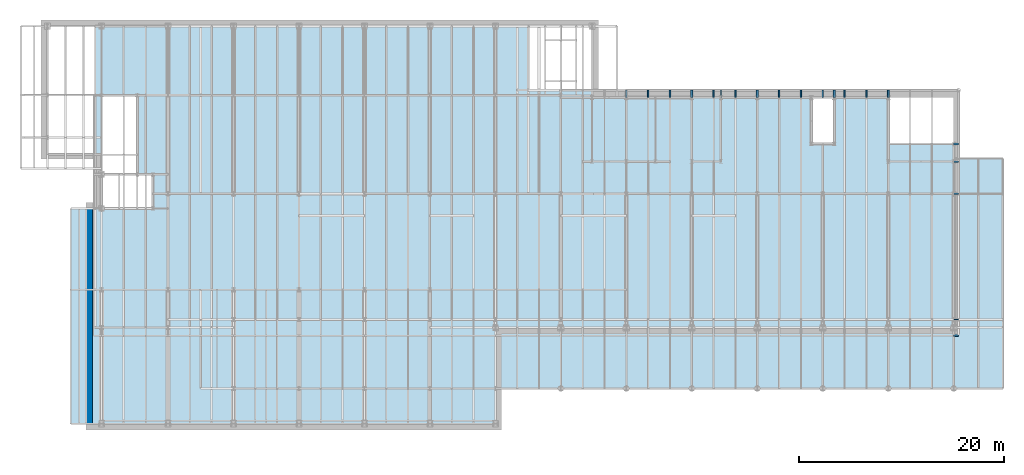
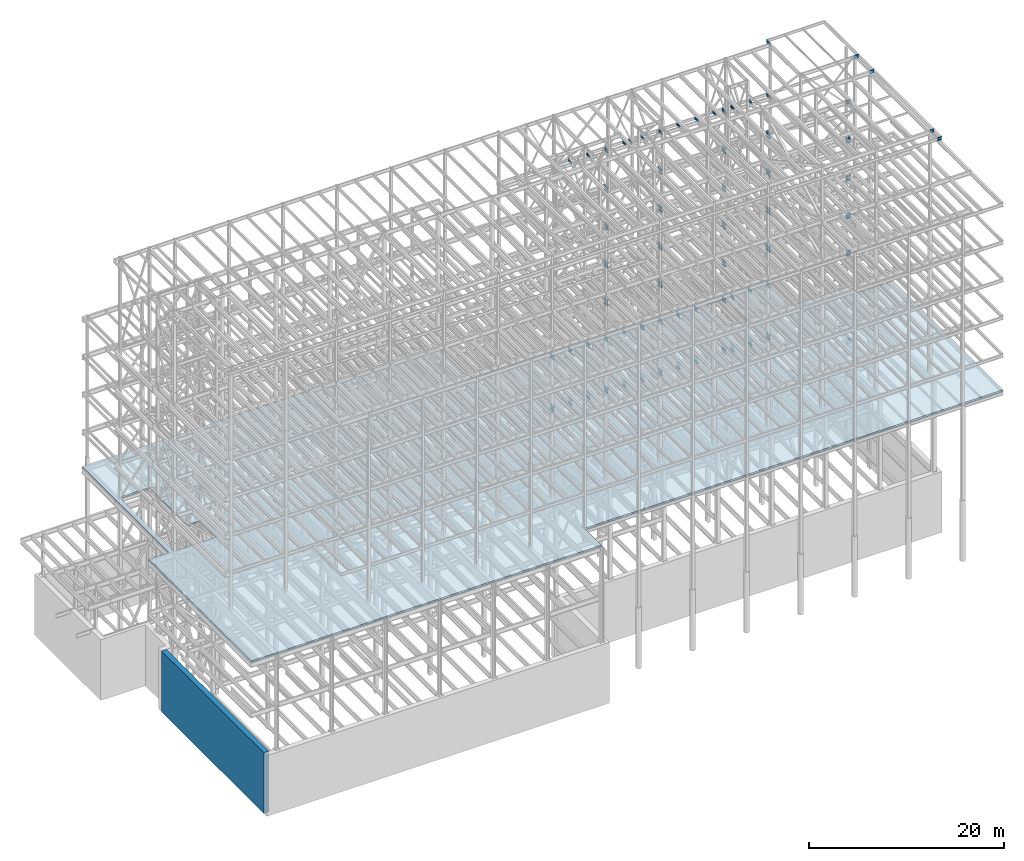
# One storey, part 149 of 150: 67 beams, 1 slab, 1 wall, 2 openings.
"""IFC2X3 building model written with IfcOpenShell, lengths in millimetres."""

from ifc_helpers import new_model, si_unit, frame, frame_2d, origin_with_axes, origin_2d_with_axis, place, context, subcontext, project, spatial, polyline, rectangle, i_section, outline, extrude, material, layer, layer_set, layer_usage, type_object, element, save


model = new_model("IFC2X3")

# Units and contexts
model_context = context("Model", 3, precision=1e-05, world=origin_with_axes())
body_context = subcontext(model_context, "Body", "Model", "MODEL_VIEW")
ifc_project = project(units=[si_unit("LENGTHUNIT", "METRE", prefix="MILLI"), si_unit("AREAUNIT", "SQUARE_METRE"), si_unit("VOLUMEUNIT", "CUBIC_METRE"), si_unit("MASSUNIT", "GRAM", prefix="KILO"), si_unit("TIMEUNIT", "SECOND"), si_unit("PLANEANGLEUNIT", "RADIAN"), si_unit("SOLIDANGLEUNIT", "STERADIAN"), si_unit("THERMODYNAMICTEMPERATUREUNIT", "DEGREE_CELSIUS"), si_unit("LUMINOUSINTENSITYUNIT", "LUMEN")], contexts=[model_context])

# Site, building, storey
site_placement = place(None, origin_with_axes())
site = spatial("IfcSite", under=ifc_project, at=site_placement, CompositionType="ELEMENT")
building_placement = place(site_placement, origin_with_axes())
building = spatial("IfcBuilding", under=site, at=building_placement, Name="Undefined", CompositionType="ELEMENT")
storey_placement = place(building_placement, origin_with_axes())
storey = spatial("IfcBuildingStorey", under=building, at=storey_placement, Name="Undefined", CompositionType="ELEMENT", Elevation=0.0)

# Beams
ifc_material_1 = material(Name="STEEL/A992")
beam_type_1 = type_object("IfcBeamType", Name="W18X35", PredefinedType="NOTDEFINED")
beam_1_placement = place(storey_placement, frame((88595.2, 27355.8, 58981.975), z_axis=(0.0, 0.0, 1.0), x_axis=(1.0, 0.0, 0.0)))
element("IfcBeam", 1, at=beam_1_placement, inside=storey, type_object=beam_type_1, material=ifc_material_1, Name="BEAM", ObjectType="W18X35", context=body_context, shape_type="SweptSolid", body=[
    extrude(i_section(OverallWidth=152.4, OverallDepth=450.85, WebThickness=7.9375, FlangeThickness=10.795, FilletRadius=17.78, at=origin_2d_with_axis()), frame((482.600000000006, 0.0, 0.0), z_axis=(-1.0, 0.0, 0.0), x_axis=(0.0, -1.0, 0.0)), (0.0, 0.0, 1.0), 482.600000000006),
])
beam_2_placement = place(storey_placement, frame((56591.2, 31877.0, 35359.975), z_axis=(0.0, 0.0, 1.0), x_axis=(0.0, 1.0, 0.0)))
element("IfcBeam", 2, at=beam_2_placement, inside=storey, type_object=beam_type_1, material=ifc_material_1, Name="BEAM", ObjectType="W18X35", context=body_context, shape_type="SweptSolid", body=[
    extrude(i_section(OverallWidth=152.4, OverallDepth=450.85, WebThickness=7.9375, FlangeThickness=10.795, FilletRadius=17.78, at=origin_2d_with_axis()), frame((736.599999999991, 0.0, 0.0), z_axis=(-1.0, 0.0, 0.0), x_axis=(0.0, -1.0, 0.0)), (0.0, 0.0, 1.0), 736.599999999991),
])
for number, where, z_axis, x_axis, name in (
    (3, (58724.8, 31877.0, 35359.975), (0.0, 0.0, 1.0), (0.0, 1.0, 0.0), "BEAM"),
    (4, (65125.59935992, 31877.0, 35359.975), (0.0, 0.0, 1.0), (0.0, 1.0, 0.0), "BEAM"),
):
    element("IfcBeam", number, at=place(storey_placement, frame(where, z_axis=z_axis, x_axis=x_axis)), inside=storey, type_object=beam_type_1, material=ifc_material_1, Name=name, ObjectType="W18X35", context=body_context, shape_type="SweptSolid", body=[
        extrude(i_section(OverallWidth=152.4, OverallDepth=450.85, WebThickness=7.9375, FlangeThickness=10.795, FilletRadius=17.78, at=origin_2d_with_axis()), frame((736.599999999991, 0.0, 0.0), z_axis=(-1.0, 0.0, 0.0), x_axis=(0.0, -1.0, 0.0)), (0.0, 0.0, 1.0), 736.599999999988),
    ])
for number, where, z_axis, x_axis, name in (
    (5, (62992.0, 31877.0, 35359.975), (0.0, 0.0, 1.0), (0.0, 1.0, 0.0), "BEAM"),
    (6, (60858.4, 31877.0, 35359.975), (0.0, 0.0, 1.0), (0.0, 1.0, 0.0), "BEAM"),
    (7, (67259.19935992, 31876.9990602, 35359.975), (0.0, 0.0, 1.0), (0.0, 1.0, 0.0), "BEAM"),
    (8, (69392.8, 31877.0, 35359.975), (0.0, 0.0, 1.0), (0.0, 1.0, 0.0), "BEAM"),
    (9, (71526.39935992, 31876.9990602, 35359.975), (0.0, 0.0, 1.0), (0.0, 1.0, 0.0), "BEAM"),
    (10, (73659.99935992, 31876.9990602, 35359.975), (0.0, 0.0, 1.0), (0.0, 1.0, 0.0), "BEAM"),
    (11, (76923.9, 31877.0, 35359.975), (0.0, 0.0, 1.0), (0.0, 1.0, 0.0), "BEAM"),
    (12, (77927.19935992, 31876.9990602, 35359.975), (0.0, 0.0, 1.0), (0.0, 1.0, 0.0), "BEAM"),
    (13, (80060.79935992, 31876.9990602, 35359.975), (0.0, 0.0, 1.0), (0.0, 1.0, 0.0), "BEAM"),
    (14, (82194.4, 31877.0, 35359.975), (0.0, 0.0, 1.0), (0.0, 1.0, 0.0), "BEAM"),
):
    element("IfcBeam", number, at=place(storey_placement, frame(where, z_axis=z_axis, x_axis=x_axis)), inside=storey, type_object=beam_type_1, material=ifc_material_1, Name=name, ObjectType="W18X35", context=body_context, shape_type="SweptSolid", body=[
        extrude(i_section(OverallWidth=152.4, OverallDepth=450.85, WebThickness=7.9375, FlangeThickness=10.795, FilletRadius=17.78, at=origin_2d_with_axis()), frame((736.599999999991, 0.0, 0.0), z_axis=(-1.0, 0.0, 0.0), x_axis=(0.0, -1.0, 0.0)), (0.0, 0.0, 1.0), 736.599999999991),
    ])
beam_type_2 = type_object("IfcBeamType", Name="W24X68", PredefinedType="NOTDEFINED")
for number, where, z_axis, x_axis, name in (
    (15, (62992.0, 31877.0, 54181.375), (0.0, 0.0, 1.0), (0.0, 1.0, 0.0), "BEAM"),
    (16, (69392.8, 31877.0, 54181.375), (0.0, 0.0, 1.0), (0.0, 1.0, 0.0), "BEAM"),
    (17, (82194.4, 31877.0, 54181.375), (0.0, 0.0, 1.0), (0.0, 1.0, 0.0), "BEAM"),
    (18, (76923.9, 31877.0, 54181.375), (0.0, 0.0, 1.0), (0.0, 1.0, 0.0), "BEAM"),
):
    element("IfcBeam", number, at=place(storey_placement, frame(where, z_axis=z_axis, x_axis=x_axis)), inside=storey, type_object=beam_type_2, material=ifc_material_1, Name=name, ObjectType="W24X68", context=body_context, shape_type="SweptSolid", body=[
        extrude(i_section(OverallWidth=227.838, OverallDepth=603.25, WebThickness=11.1125, FlangeThickness=14.859, FilletRadius=23.2409, at=origin_2d_with_axis()), frame((736.599999999991, 0.0, 0.0), z_axis=(-1.0, 0.0, 0.0), x_axis=(0.0, -1.0, 0.0)), (0.0, 0.0, 1.0), 736.599999999991),
    ])
beam_3_placement = place(storey_placement, frame((88595.2, 27355.8, 54181.375), z_axis=(0.0, 0.0, 1.0), x_axis=(1.0, 0.0, 0.0)))
element("IfcBeam", 19, at=beam_3_placement, inside=storey, type_object=beam_type_2, material=ifc_material_1, Name="BEAM", ObjectType="W24X68", context=body_context, shape_type="SweptSolid", body=[
    extrude(i_section(OverallWidth=227.838, OverallDepth=603.25, WebThickness=11.1125, FlangeThickness=14.859, FilletRadius=23.2409, at=origin_2d_with_axis()), frame((482.600000000006, 0.0, 0.0), z_axis=(-1.0, 0.0, 0.0), x_axis=(0.0, -1.0, 0.0)), (0.0, 0.0, 1.0), 482.600000000006),
])
for number, where, z_axis, x_axis, name in (
    (20, (62992.0, 31877.0, 49456.975), (0.0, 0.0, 1.0), (0.0, 1.0, 0.0), "BEAM"),
    (21, (69392.8, 31877.0, 49456.975), (0.0, 0.0, 1.0), (0.0, 1.0, 0.0), "BEAM"),
    (22, (82194.4, 31877.0, 49456.975), (0.0, 0.0, 1.0), (0.0, 1.0, 0.0), "BEAM"),
    (23, (76923.9, 31877.0, 49456.975), (0.0, 0.0, 1.0), (0.0, 1.0, 0.0), "BEAM"),
):
    element("IfcBeam", number, at=place(storey_placement, frame(where, z_axis=z_axis, x_axis=x_axis)), inside=storey, type_object=beam_type_2, material=ifc_material_1, Name=name, ObjectType="W24X68", context=body_context, shape_type="SweptSolid", body=[
        extrude(i_section(OverallWidth=227.838, OverallDepth=603.25, WebThickness=11.1125, FlangeThickness=14.859, FilletRadius=23.2409, at=origin_2d_with_axis()), frame((736.599999999991, 0.0, 0.0), z_axis=(-1.0, 0.0, 0.0), x_axis=(0.0, -1.0, 0.0)), (0.0, 0.0, 1.0), 736.599999999991),
    ])
beam_4_placement = place(storey_placement, frame((88595.2, 27355.8, 49456.975), z_axis=(0.0, 0.0, 1.0), x_axis=(1.0, 0.0, 0.0)))
element("IfcBeam", 24, at=beam_4_placement, inside=storey, type_object=beam_type_2, material=ifc_material_1, Name="BEAM", ObjectType="W24X68", context=body_context, shape_type="SweptSolid", body=[
    extrude(i_section(OverallWidth=227.838, OverallDepth=603.25, WebThickness=11.1125, FlangeThickness=14.859, FilletRadius=23.2409, at=origin_2d_with_axis()), frame((482.600000000006, 0.0, 0.0), z_axis=(-1.0, 0.0, 0.0), x_axis=(0.0, -1.0, 0.0)), (0.0, 0.0, 1.0), 482.600000000006),
])
for number, where, z_axis, x_axis, name in (
    (25, (62992.0, 31877.0, 44732.575), (0.0, 0.0, 1.0), (0.0, 1.0, 0.0), "BEAM"),
    (26, (69392.8, 31877.0, 44732.575), (0.0, 0.0, 1.0), (0.0, 1.0, 0.0), "BEAM"),
    (27, (82194.4, 31877.0, 44732.575), (0.0, 0.0, 1.0), (0.0, 1.0, 0.0), "BEAM"),
    (28, (76923.9, 31877.0, 44732.575), (0.0, 0.0, 1.0), (0.0, 1.0, 0.0), "BEAM"),
):
    element("IfcBeam", number, at=place(storey_placement, frame(where, z_axis=z_axis, x_axis=x_axis)), inside=storey, type_object=beam_type_2, material=ifc_material_1, Name=name, ObjectType="W24X68", context=body_context, shape_type="SweptSolid", body=[
        extrude(i_section(OverallWidth=227.838, OverallDepth=603.25, WebThickness=11.1125, FlangeThickness=14.859, FilletRadius=23.2409, at=origin_2d_with_axis()), frame((736.599999999991, 0.0, 0.0), z_axis=(-1.0, 0.0, 0.0), x_axis=(0.0, -1.0, 0.0)), (0.0, 0.0, 1.0), 736.599999999991),
    ])
beam_5_placement = place(storey_placement, frame((88595.2, 27355.8, 44732.575), z_axis=(0.0, 0.0, 1.0), x_axis=(1.0, 0.0, 0.0)))
element("IfcBeam", 29, at=beam_5_placement, inside=storey, type_object=beam_type_2, material=ifc_material_1, Name="BEAM", ObjectType="W24X68", context=body_context, shape_type="SweptSolid", body=[
    extrude(i_section(OverallWidth=227.838, OverallDepth=603.25, WebThickness=11.1125, FlangeThickness=14.859, FilletRadius=23.2409, at=origin_2d_with_axis()), frame((482.600000000006, 0.0, 0.0), z_axis=(-1.0, 0.0, 0.0), x_axis=(0.0, -1.0, 0.0)), (0.0, 0.0, 1.0), 482.600000000006),
])
for number, where, z_axis, x_axis, name in (
    (30, (62992.0, 31877.0, 40008.175), (0.0, 0.0, 1.0), (0.0, 1.0, 0.0), "BEAM"),
    (31, (69392.8, 31877.0, 40008.175), (0.0, 0.0, 1.0), (0.0, 1.0, 0.0), "BEAM"),
    (32, (82194.4, 31877.0, 40008.175), (0.0, 0.0, 1.0), (0.0, 1.0, 0.0), "BEAM"),
    (33, (76923.9, 31877.0, 40008.175), (0.0, 0.0, 1.0), (0.0, 1.0, 0.0), "BEAM"),
):
    element("IfcBeam", number, at=place(storey_placement, frame(where, z_axis=z_axis, x_axis=x_axis)), inside=storey, type_object=beam_type_2, material=ifc_material_1, Name=name, ObjectType="W24X68", context=body_context, shape_type="SweptSolid", body=[
        extrude(i_section(OverallWidth=227.838, OverallDepth=603.25, WebThickness=11.1125, FlangeThickness=14.859, FilletRadius=23.2409, at=origin_2d_with_axis()), frame((736.599999999991, 0.0, 0.0), z_axis=(-1.0, 0.0, 0.0), x_axis=(0.0, -1.0, 0.0)), (0.0, 0.0, 1.0), 736.599999999991),
    ])
beam_6_placement = place(storey_placement, frame((88595.2, 27355.8, 40008.175), z_axis=(0.0, 0.0, 1.0), x_axis=(1.0, 0.0, 0.0)))
element("IfcBeam", 34, at=beam_6_placement, inside=storey, type_object=beam_type_2, material=ifc_material_1, Name="BEAM", ObjectType="W24X68", context=body_context, shape_type="SweptSolid", body=[
    extrude(i_section(OverallWidth=227.838, OverallDepth=603.25, WebThickness=11.1125, FlangeThickness=14.859, FilletRadius=23.2409, at=origin_2d_with_axis()), frame((482.600000000006, 0.0, 0.0), z_axis=(-1.0, 0.0, 0.0), x_axis=(0.0, -1.0, 0.0)), (0.0, 0.0, 1.0), 482.600000000006),
])
beam_type_3 = type_object("IfcBeamType", Name="W14X22", PredefinedType="NOTDEFINED")
for number, where, z_axis, x_axis, name in (
    (35, (88595.2, 8610.6, 65738.375), (0.0, 0.0, 1.0), (1.0, 0.0, 0.0), "BEAM"),
    (36, (88595.2, 10185.4, 65738.375), (0.0, 0.0, 1.0), (1.0, 0.0, 0.0), "BEAM"),
    (37, (88595.2, 22479.0, 65738.375), (0.0, 0.0, 1.0), (1.0, 0.0, 0.0), "BEAM"),
    (38, (88595.2, 25628.6, 65738.375), (0.0, 0.0, 1.0), (1.0, 0.0, 0.0), "BEAM"),
):
    element("IfcBeam", number, at=place(storey_placement, frame(where, z_axis=z_axis, x_axis=x_axis)), inside=storey, type_object=beam_type_3, material=ifc_material_1, Name=name, ObjectType="W14X22", context=body_context, shape_type="SweptSolid", body=[
        extrude(i_section(OverallWidth=127.0, OverallDepth=349.25, WebThickness=6.3499, FlangeThickness=8.509, FilletRadius=18.4785, at=origin_2d_with_axis()), frame((482.600000000006, 0.0, 0.0), z_axis=(-1.0, 0.0, 0.0), x_axis=(0.0, -1.0, 0.0)), (0.0, 0.0, 1.0), 482.600000000006),
    ])
for number, where, z_axis, x_axis, name in (
    (39, (82194.4, 31877.0, 65738.375), (0.0, 0.0, 1.0), (0.0, 1.0, 0.0), "BEAM"),
    (40, (62991.99935992, 31877.0, 59032.775), (0.0, 0.0, 1.0), (0.0, 1.0, 0.0), "BEAM"),
    (41, (69392.8, 31877.0, 59032.775), (0.0, 0.0, 1.0), (0.0, 1.0, 0.0), "BEAM"),
    (42, (76923.9, 31877.0, 59032.775), (0.0, 0.0, 1.0), (0.0, 1.0, 0.0), "BEAM"),
    (43, (82194.4, 31877.0, 59032.775), (0.0, 0.0, 1.0), (0.0, 1.0, 0.0), "BEAM"),
):
    element("IfcBeam", number, at=place(storey_placement, frame(where, z_axis=z_axis, x_axis=x_axis)), inside=storey, type_object=beam_type_3, material=ifc_material_1, Name=name, ObjectType="W14X22", context=body_context, shape_type="SweptSolid", body=[
        extrude(i_section(OverallWidth=127.0, OverallDepth=349.25, WebThickness=6.3499, FlangeThickness=8.509, FilletRadius=18.4785, at=origin_2d_with_axis()), frame((736.599999999991, 0.0, 0.0), z_axis=(-1.0, 0.0, 0.0), x_axis=(0.0, -1.0, 0.0)), (0.0, 0.0, 1.0), 736.599999999991),
    ])
beam_type_4 = type_object("IfcBeamType", Name="W10X15", PredefinedType="NOTDEFINED")
for number, where, z_axis, x_axis, name in (
    (44, (58724.8, 31877.0, 59080.4), (0.0, 0.0, 1.0), (0.0, 1.0, 0.0), "BEAM"),
    (45, (60858.4, 31877.0, 59080.4), (0.0, 0.0, 1.0), (0.0, 1.0, 0.0), "BEAM"),
    (46, (65125.6, 31877.0, 59080.4), (0.0, 0.0, 1.0), (0.0, 1.0, 0.0), "BEAM"),
    (47, (65836.8, 31877.0, 59080.4), (0.0, 0.0, 1.0), (0.0, 1.0, 0.0), "BEAM"),
    (48, (67259.2, 31877.0, 59080.4), (0.0, 0.0, 1.0), (0.0, 1.0, 0.0), "BEAM"),
    (49, (71526.4, 31877.0, 59080.4), (0.0, 0.0, 1.0), (0.0, 1.0, 0.0), "BEAM"),
    (50, (73660.0, 31877.0, 59080.4), (0.0, 0.0, 1.0), (0.0, 1.0, 0.0), "BEAM"),
    (51, (75793.6, 31877.0, 59080.4), (0.0, 0.0, 1.0), (0.0, 1.0, 0.0), "BEAM"),
    (52, (77927.2, 31877.0, 59080.4), (0.0, 0.0, 1.0), (0.0, 1.0, 0.0), "BEAM"),
    (53, (80060.8, 31877.0, 59080.4), (0.0, 0.0, 1.0), (0.0, 1.0, 0.0), "BEAM"),
):
    element("IfcBeam", number, at=place(storey_placement, frame(where, z_axis=z_axis, x_axis=x_axis)), inside=storey, type_object=beam_type_4, material=ifc_material_1, Name=name, ObjectType="W10X15", context=body_context, shape_type="SweptSolid", body=[
        extrude(i_section(OverallWidth=101.6, OverallDepth=254.0, WebThickness=6.3499, FlangeThickness=6.858, FilletRadius=13.7795, at=origin_2d_with_axis()), frame((736.599999999991, 0.0, 0.0), z_axis=(-1.0, 0.0, 0.0), x_axis=(0.0, -1.0, 0.0)), (0.0, 0.0, 1.0), 736.599999999991),
    ])
beam_type_5 = type_object("IfcBeamType", Name="W24X55", PredefinedType="NOTDEFINED")
beam_7_placement = place(storey_placement, frame((88595.2, 27355.8, 28986.1625), z_axis=(0.0, 0.0, 1.0), x_axis=(1.0, 0.0, 0.0)))
element("IfcBeam", 54, at=beam_7_placement, inside=storey, type_object=beam_type_5, material=ifc_material_1, Name="BEAM", ObjectType="W24X55", context=body_context, shape_type="SweptSolid", body=[
    extrude(i_section(OverallWidth=178.054, OverallDepth=600.075, WebThickness=9.5249, FlangeThickness=12.827, FilletRadius=23.6854, at=origin_2d_with_axis()), frame((482.600000000006, 0.0, 0.0), z_axis=(-1.0, 0.0, 0.0), x_axis=(0.0, -1.0, 0.0)), (0.0, 0.0, 1.0), 482.600000000006),
])
for number, where, z_axis, x_axis, name in (
    (55, (80060.8, 31877.0, 28986.1625), (0.0, 0.0, 1.0), (0.0, 1.0, 0.0), "BEAM"),
    (56, (77927.2, 31877.0, 28986.1625), (0.0, 0.0, 1.0), (0.0, 1.0, 0.0), "BEAM"),
    (57, (82194.4, 31877.0, 28986.1625), (0.0, 0.0, 1.0), (0.0, 1.0, 0.0), "BEAM"),
    (58, (73660.0, 31877.0, 28986.1625), (0.0, 0.0, 1.0), (0.0, 1.0, 0.0), "BEAM"),
    (59, (71526.4, 31877.0, 28986.1625), (0.0, 0.0, 1.0), (0.0, 1.0, 0.0), "BEAM"),
    (60, (76923.9, 31877.0, 28986.1625), (0.0, 0.0, 1.0), (0.0, 1.0, 0.0), "BEAM"),
    (61, (67259.2, 31877.0, 28986.1625), (0.0, 0.0, 1.0), (0.0, 1.0, 0.0), "BEAM"),
    (62, (65125.6, 31877.0, 28986.1625), (0.0, 0.0, 1.0), (0.0, 1.0, 0.0), "BEAM"),
    (63, (69392.8, 31877.0, 28986.1625), (0.0, 0.0, 1.0), (0.0, 1.0, 0.0), "BEAM"),
    (64, (60858.4, 31877.0, 28986.1625), (0.0, 0.0, 1.0), (0.0, 1.0, 0.0), "BEAM"),
    (65, (58724.8, 31877.0, 28986.1625), (0.0, 0.0, 1.0), (0.0, 1.0, 0.0), "BEAM"),
    (66, (62992.0, 31877.0, 28986.1625), (0.0, 0.0, 1.0), (0.0, 1.0, 0.0), "BEAM"),
    (67, (56591.2, 31877.0, 28986.1625), (0.0, 0.0, 1.0), (0.0, 1.0, 0.0), "BEAM"),
):
    element("IfcBeam", number, at=place(storey_placement, frame(where, z_axis=z_axis, x_axis=x_axis)), inside=storey, type_object=beam_type_5, material=ifc_material_1, Name=name, ObjectType="W24X55", context=body_context, shape_type="SweptSolid", body=[
        extrude(i_section(OverallWidth=178.054, OverallDepth=600.075, WebThickness=9.5249, FlangeThickness=12.827, FilletRadius=23.6854, at=origin_2d_with_axis()), frame((736.599999999991, 0.0, 0.0), z_axis=(-1.0, 0.0, 0.0), x_axis=(0.0, -1.0, 0.0)), (0.0, 0.0, 1.0), 736.599999999991),
    ])

# Slab, openings
ifc_material_2 = material(Name="CONCRETE/5000")
ifc_layer_1 = layer(ifc_material_2, 203.2)
ifc_layer_set_1 = layer_set([ifc_layer_1], Name="Floor: Insitu CONCRETE")
ifc_layer_usage_1 = layer_usage(ifc_layer_set_1, "AXIS3", "POSITIVE", -101.6)
slab_type = type_object("IfcSlabType", PredefinedType="NOTDEFINED")
slab_placement = place(storey_placement, frame((2286.0, 0.0, 35687.0), z_axis=(0.0, 0.0, 1.0), x_axis=(1.0, 0.0, 0.0)))
slab = element("IfcSlab", 68, at=slab_placement, inside=storey, type_object=slab_type, material=ifc_layer_usage_1, Name="SLAB", PredefinedType="FLOOR", context=body_context, shape_type="SweptSolid", body=[
    extrude(outline(polyline([(0.0, 0.0), (41503.6015625, 0.0), (41503.6015625, 3454.39990234375), (91109.796875, 3454.39990234375), (91109.796875, 25628.599609375), (91109.796875, 25933.400390625), (86791.796875, 25933.400390625), (86791.796875, 27355.80078125), (79908.3984375, 27355.80078125), (79908.3984375, 32613.599609375), (44704.0, 32613.599609375), (44704.0, 38862.0), (2387.60009765625, 38862.0), (2387.60009765625, 21043.900390625), (0.0, 21043.900390625), (0.0, 0.0)])), frame((0.0, 0.0, -101.6), z_axis=(0.0, 0.0, 1.0), x_axis=(1.0, 0.0, 0.0)), (0.0, 0.0, 1.0), 203.2),
])
opening_1_placement = place(storey_placement, frame((2286.0, 0.0, 35687.0), z_axis=(0.0, 0.0, 1.0), x_axis=(1.0, 0.0, 0.0)))
element("IfcOpeningElement", 69, at=opening_1_placement, cuts=slab, ObjectType="Recess", context=body_context, shape_type="SweptSolid", body=[
    extrude(outline(polyline([(0.0, 0.0), (5029.19970703125, -3.63797880709171e-12), (5029.19970703125, 3340.099609375), (3505.1982421875, 3340.099609375), (3505.19897460938, 11087.099609375), (0.0, 11087.099609375), (0.0, 0.0)])), frame((2997.2, 21043.9, -104.5), z_axis=(0.0, 0.0, 1.0), x_axis=(1.0, 0.0, 0.0)), (0.0, 0.0, 1.0), 209.0),
])
opening_2_placement = place(storey_placement, frame((2286.0, 0.0, 35687.0), z_axis=(0.0, 0.0, 1.0), x_axis=(1.0, 0.0, 0.0)))
element("IfcOpeningElement", 70, at=opening_2_placement, cuts=slab, ObjectType="Recess", context=body_context, shape_type="SweptSolid", body=[
    extrude(outline(polyline([(0.0, 0.0), (2260.599609375, 0.0), (2260.60009765625, 4521.2001953125), (0.0, 4521.2001953125), (0.0, 0.0)])), frame((72377.3, 27355.8, -104.5), z_axis=(0.0, 0.0, 1.0), x_axis=(1.0, 0.0, 0.0)), (0.0, 0.0, 1.0), 209.0),
])

# Wall
ifc_layer_2 = layer(ifc_material_2, 609.6)
ifc_layer_set_2 = layer_set([ifc_layer_2], Name="Wall: Insitu CONCRETE")
ifc_layer_usage_2 = layer_usage(ifc_layer_set_2, "AXIS2", "POSITIVE", -304.8)
wall_type = type_object("IfcWallType", PredefinedType="NOTDEFINED")
wall_placement = place(storey_placement, frame((4089.4, 1.31731276025183e-14, 16154.4), z_axis=(0.0, 0.0, 1.0), x_axis=(0.0, 1.0, 0.0)))
element("IfcWallStandardCase", 71, at=wall_placement, inside=storey, type_object=wall_type, material=ifc_layer_usage_2, Name="WALL", context=body_context, shape_type="SweptSolid", body=[
    extrude(rectangle(XDim=21043.900390625, YDim=609.6, at=frame_2d((0.0, 10521.9501953125), x_axis=(0.0, -1.0))), frame((0.0, 0.0, 0.0), z_axis=(0.0, 0.0, 1.0), x_axis=(0.0, -1.0, 0.0)), (0.0, 0.0, 1.0), 7620.0),
])

save(model, "model.ifc")
